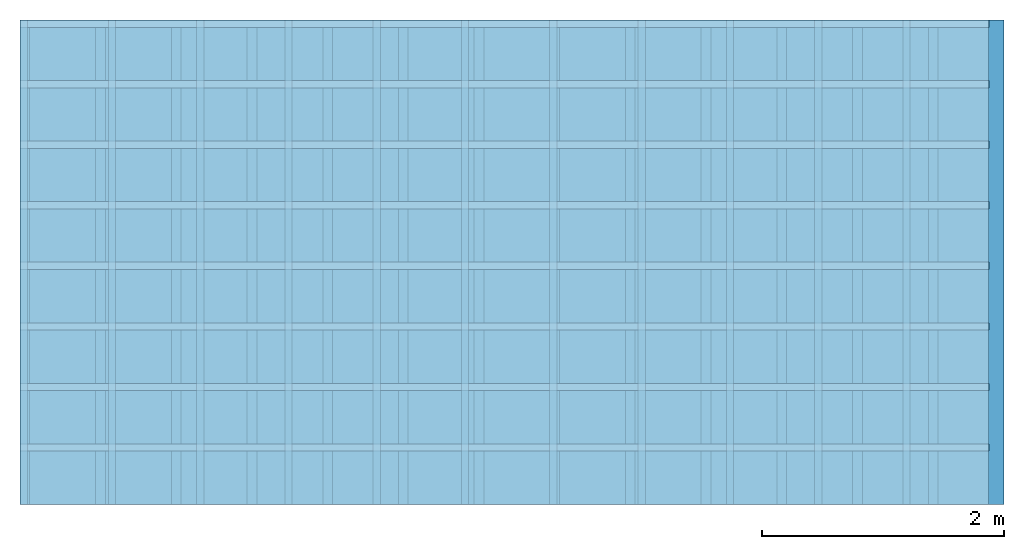
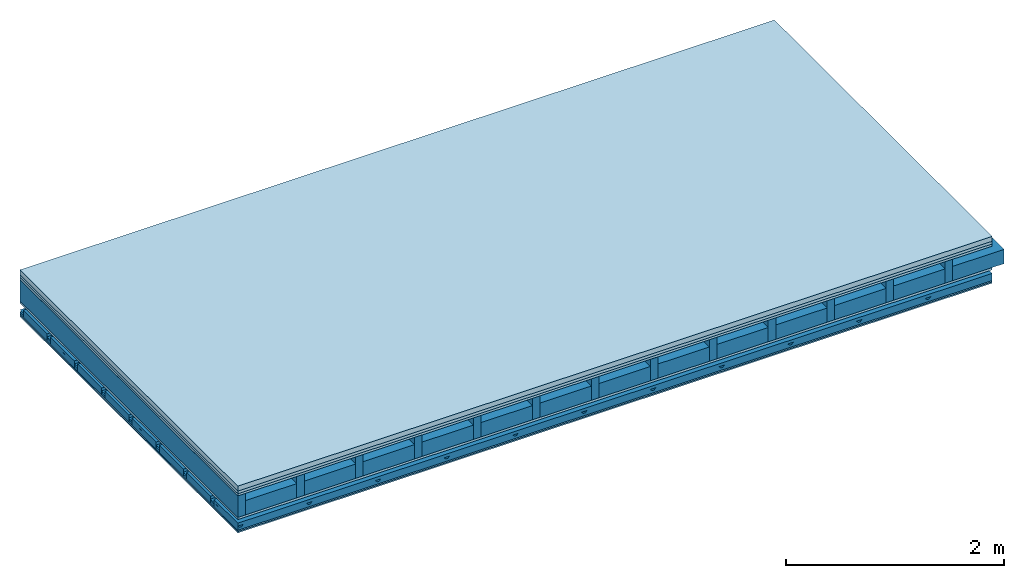
# One storey: 6 plates, 5 members, 1 element without a shape of its own.
"""IFC4 building model written with IfcOpenShell, lengths in metres."""

from ifc_helpers import new_model, si_unit, derived_unit, direction, frame, frame_2d, origin, origin_with_axes, place, context, project, spatial, polyline, rectangle, outline, extrude, material, layer, layer_set, type_object, element, aggregate, save


model = new_model("IFC4")

# Units and contexts
plan_context = context("Plan", 3, precision=1e-05, world=origin(), true_north=direction((0.0, 1.0)))
model_context = context("Model", 3, precision=1e-05, world=origin(), true_north=direction((0.0, 1.0)))
ifc_project = project(units=[si_unit("LENGTHUNIT", "METRE"), derived_unit("SOUNDPRESSUREUNIT", [(si_unit("PRESSUREUNIT", "PASCAL", prefix="MICRO"), 0)]), si_unit("ENERGYUNIT", "JOULE", prefix="MEGA"), si_unit("MASSUNIT", "GRAM", prefix="KILO"), derived_unit("THERMALTRANSMITTANCEUNIT", [(si_unit("POWERUNIT", "WATT"), 1), (si_unit("AREAUNIT", "SQUARE_METRE"), -1), (si_unit("THERMODYNAMICTEMPERATUREUNIT", "KELVIN"), -1)]), derived_unit("AREADENSITYUNIT", [(si_unit("MASSUNIT", "GRAM", prefix="KILO"), 1), (si_unit("AREAUNIT", "SQUARE_METRE"), -1)]), derived_unit("USERDEFINED", [(si_unit("ENERGYUNIT", "JOULE", prefix="MEGA"), 1), (si_unit("AREAUNIT", "SQUARE_METRE"), -1)])], contexts=[plan_context, model_context])

# Site, building, storey
site = spatial("IfcSite", under=ifc_project)
building_placement = place(None, origin())
building = spatial("IfcBuilding", under=site, at=building_placement)
storey_placement = place(building_placement, origin())
storey = spatial("IfcBuildingStorey", under=building, at=storey_placement)

# Slab, members, plates
ifc_material_1 = material(Category="04.005")
ifc_layer_1 = layer(ifc_material_1, 0.055, Name="On-material")
ifc_material_2 = material()
ifc_layer_2 = layer(ifc_material_2, 0.03, Name="Impact sound insulation")
ifc_material_3 = material(Category="07.001")
ifc_layer_3 = layer(ifc_material_3, 0.025, Name="Sub-floor")
ifc_material_4 = material(Name="Rigid, of the art")
ifc_layer_4 = layer(ifc_material_4, 0.0, Name="Bond")
ifc_layer_5 = layer(None, 0.24, Name="Supporting structure")
ifc_layer_6 = layer(ifc_material_4, 0.0, Name="Bond")
ifc_layer_7 = layer(ifc_material_3, 0.025, Name="Lower layer 1")
ifc_layer_8 = layer(None, 0.093, Name="Coupling")
ifc_layer_9 = layer(None, 0.027, Name="Battens / profiles")
ifc_material_5 = material(Category="03.007")
ifc_layer_10 = layer(ifc_material_5, 0.015, Name="Ceiling covering 1st layer")
ifc_layer_11 = layer(ifc_material_5, 0.015, Name="Ceiling covering layer 2")
ifc_material_6 = material(Name="Glued joints")
ifc_layer_12 = layer(ifc_material_6, 0.0, Name="Surface / treatment")
ifc_layer_set = layer_set([ifc_layer_1, ifc_layer_2, ifc_layer_3, ifc_layer_4, ifc_layer_5, ifc_layer_6, ifc_layer_7, ifc_layer_8, ifc_layer_9, ifc_layer_10, ifc_layer_11, ifc_layer_12])
slab_type = type_object("IfcSlabType", Name="A0760", PredefinedType="NOTDEFINED", material=ifc_layer_set)
slab_placement = place(None, frame((0.0, 0.0, 0.0), z_axis=(0.0, 0.0, -1.0), x_axis=(1.0, 0.0, 0.0)))
slab = element("IfcSlab", 1, at=slab_placement, inside=storey, type_object=slab_type, material=ifc_layer_set, Name="Slab #1")
ifc_material_7 = material()
member_1_placement = place(slab_placement, origin())
member_1 = element("IfcMember", 2, at=member_1_placement, material=ifc_material_7, Name="Supporting structure", context=plan_context, shape_type="SweptSolid", body=[
    extrude(rectangle(XDim=0.08, YDim=0.24, at=frame_2d((0.04, 0.12), x_axis=(1.0, 0.0))), frame((0.0, 4.0, 0.11), z_axis=(0.0, -1.0, 0.0), x_axis=(1.0, 0.0, 0.0)), (0.0, 0.0, 1.0), 4.0),
    extrude(rectangle(XDim=0.08, YDim=0.24, at=frame_2d((0.04, 0.12), x_axis=(1.0, 0.0))), frame((0.625, 4.0, 0.11), z_axis=(0.0, -1.0, 0.0), x_axis=(1.0, 0.0, 0.0)), (0.0, 0.0, 1.0), 4.0),
    extrude(rectangle(XDim=0.08, YDim=0.24, at=frame_2d((0.04, 0.12), x_axis=(1.0, 0.0))), frame((1.25, 4.0, 0.11), z_axis=(0.0, -1.0, 0.0), x_axis=(1.0, 0.0, 0.0)), (0.0, 0.0, 1.0), 4.0),
    extrude(rectangle(XDim=0.08, YDim=0.24, at=frame_2d((0.04, 0.12), x_axis=(1.0, 0.0))), frame((1.875, 4.0, 0.11), z_axis=(0.0, -1.0, 0.0), x_axis=(1.0, 0.0, 0.0)), (0.0, 0.0, 1.0), 4.0),
    extrude(rectangle(XDim=0.08, YDim=0.24, at=frame_2d((0.04, 0.12), x_axis=(1.0, 0.0))), frame((2.5, 4.0, 0.11), z_axis=(0.0, -1.0, 0.0), x_axis=(1.0, 0.0, 0.0)), (0.0, 0.0, 1.0), 4.0),
    extrude(rectangle(XDim=0.08, YDim=0.24, at=frame_2d((0.04, 0.12), x_axis=(1.0, 0.0))), frame((3.125, 4.0, 0.11), z_axis=(0.0, -1.0, 0.0), x_axis=(1.0, 0.0, 0.0)), (0.0, 0.0, 1.0), 4.0),
    extrude(rectangle(XDim=0.08, YDim=0.24, at=frame_2d((0.04, 0.12), x_axis=(1.0, 0.0))), frame((3.75, 4.0, 0.11), z_axis=(0.0, -1.0, 0.0), x_axis=(1.0, 0.0, 0.0)), (0.0, 0.0, 1.0), 4.0),
    extrude(rectangle(XDim=0.08, YDim=0.24, at=frame_2d((0.04, 0.12), x_axis=(1.0, 0.0))), frame((4.375, 4.0, 0.11), z_axis=(0.0, -1.0, 0.0), x_axis=(1.0, 0.0, 0.0)), (0.0, 0.0, 1.0), 4.0),
    extrude(rectangle(XDim=0.08, YDim=0.24, at=frame_2d((0.04, 0.12), x_axis=(1.0, 0.0))), frame((5.0, 4.0, 0.11), z_axis=(0.0, -1.0, 0.0), x_axis=(1.0, 0.0, 0.0)), (0.0, 0.0, 1.0), 4.0),
    extrude(rectangle(XDim=0.08, YDim=0.24, at=frame_2d((0.04, 0.12), x_axis=(1.0, 0.0))), frame((5.625, 4.0, 0.11), z_axis=(0.0, -1.0, 0.0), x_axis=(1.0, 0.0, 0.0)), (0.0, 0.0, 1.0), 4.0),
    extrude(rectangle(XDim=0.08, YDim=0.24, at=frame_2d((0.04, 0.12), x_axis=(1.0, 0.0))), frame((6.25, 4.0, 0.11), z_axis=(0.0, -1.0, 0.0), x_axis=(1.0, 0.0, 0.0)), (0.0, 0.0, 1.0), 4.0),
    extrude(rectangle(XDim=0.08, YDim=0.24, at=frame_2d((0.04, 0.12), x_axis=(1.0, 0.0))), frame((6.875, 4.0, 0.11), z_axis=(0.0, -1.0, 0.0), x_axis=(1.0, 0.0, 0.0)), (0.0, 0.0, 1.0), 4.0),
    extrude(rectangle(XDim=0.08, YDim=0.24, at=frame_2d((0.04, 0.12), x_axis=(1.0, 0.0))), frame((7.5, 4.0, 0.11), z_axis=(0.0, -1.0, 0.0), x_axis=(1.0, 0.0, 0.0)), (0.0, 0.0, 1.0), 4.0),
])
ifc_material_8 = material()
member_2_placement = place(slab_placement, origin())
member_2 = element("IfcMember", 3, at=member_2_placement, material=ifc_material_8, Name="in supporting structure", context=plan_context, shape_type="SweptSolid", body=[
    extrude(rectangle(XDim=0.545, YDim=0.16, at=frame_2d((0.2725, 0.08), x_axis=(1.0, 0.0))), frame((0.08, 4.0, 0.19), z_axis=(0.0, -1.0, 0.0), x_axis=(1.0, 0.0, 0.0)), (0.0, 0.0, 1.0), 4.0),
    extrude(rectangle(XDim=0.545, YDim=0.16, at=frame_2d((0.2725, 0.08), x_axis=(1.0, 0.0))), frame((0.705, 4.0, 0.19), z_axis=(0.0, -1.0, 0.0), x_axis=(1.0, 0.0, 0.0)), (0.0, 0.0, 1.0), 4.0),
    extrude(rectangle(XDim=0.545, YDim=0.16, at=frame_2d((0.2725, 0.08), x_axis=(1.0, 0.0))), frame((1.33, 4.0, 0.19), z_axis=(0.0, -1.0, 0.0), x_axis=(1.0, 0.0, 0.0)), (0.0, 0.0, 1.0), 4.0),
    extrude(rectangle(XDim=0.545, YDim=0.16, at=frame_2d((0.2725, 0.08), x_axis=(1.0, 0.0))), frame((1.955, 4.0, 0.19), z_axis=(0.0, -1.0, 0.0), x_axis=(1.0, 0.0, 0.0)), (0.0, 0.0, 1.0), 4.0),
    extrude(rectangle(XDim=0.545, YDim=0.16, at=frame_2d((0.2725, 0.08), x_axis=(1.0, 0.0))), frame((2.58, 4.0, 0.19), z_axis=(0.0, -1.0, 0.0), x_axis=(1.0, 0.0, 0.0)), (0.0, 0.0, 1.0), 4.0),
    extrude(rectangle(XDim=0.545, YDim=0.16, at=frame_2d((0.2725, 0.08), x_axis=(1.0, 0.0))), frame((3.205, 4.0, 0.19), z_axis=(0.0, -1.0, 0.0), x_axis=(1.0, 0.0, 0.0)), (0.0, 0.0, 1.0), 4.0),
    extrude(rectangle(XDim=0.545, YDim=0.16, at=frame_2d((0.2725, 0.08), x_axis=(1.0, 0.0))), frame((3.83, 4.0, 0.19), z_axis=(0.0, -1.0, 0.0), x_axis=(1.0, 0.0, 0.0)), (0.0, 0.0, 1.0), 4.0),
    extrude(rectangle(XDim=0.545, YDim=0.16, at=frame_2d((0.2725, 0.08), x_axis=(1.0, 0.0))), frame((4.455, 4.0, 0.19), z_axis=(0.0, -1.0, 0.0), x_axis=(1.0, 0.0, 0.0)), (0.0, 0.0, 1.0), 4.0),
    extrude(rectangle(XDim=0.545, YDim=0.16, at=frame_2d((0.2725, 0.08), x_axis=(1.0, 0.0))), frame((5.08, 4.0, 0.19), z_axis=(0.0, -1.0, 0.0), x_axis=(1.0, 0.0, 0.0)), (0.0, 0.0, 1.0), 4.0),
    extrude(rectangle(XDim=0.545, YDim=0.16, at=frame_2d((0.2725, 0.08), x_axis=(1.0, 0.0))), frame((5.705, 4.0, 0.19), z_axis=(0.0, -1.0, 0.0), x_axis=(1.0, 0.0, 0.0)), (0.0, 0.0, 1.0), 4.0),
    extrude(rectangle(XDim=0.545, YDim=0.16, at=frame_2d((0.2725, 0.08), x_axis=(1.0, 0.0))), frame((6.33, 4.0, 0.19), z_axis=(0.0, -1.0, 0.0), x_axis=(1.0, 0.0, 0.0)), (0.0, 0.0, 1.0), 4.0),
    extrude(rectangle(XDim=0.545, YDim=0.16, at=frame_2d((0.2725, 0.08), x_axis=(1.0, 0.0))), frame((6.955, 4.0, 0.19), z_axis=(0.0, -1.0, 0.0), x_axis=(1.0, 0.0, 0.0)), (0.0, 0.0, 1.0), 4.0),
    extrude(rectangle(XDim=0.545, YDim=0.16, at=frame_2d((0.2725, 0.08), x_axis=(1.0, 0.0))), frame((7.58, 4.0, 0.19), z_axis=(0.0, -1.0, 0.0), x_axis=(1.0, 0.0, 0.0)), (0.0, 0.0, 1.0), 4.0),
])
ifc_material_9 = material()
member_3_placement = place(slab_placement, origin())
member_3 = element("IfcMember", 4, at=member_3_placement, material=ifc_material_9, Name="Coupling", context=plan_context, shape_type="SweptSolid", body=[
    extrude(outline(polyline([(0.0, 0.0), (0.06, 0.0), (0.04, 0.02), (0.02, 0.02), (0.0, 0.0)])), frame((0.0, 4.0, 0.448), z_axis=(0.0, -1.0, 0.0), x_axis=(1.0, 0.0, 0.0)), (0.0, 0.0, 1.0), 4.0),
    extrude(outline(polyline([(0.0, 0.0), (0.06, 0.0), (0.04, 0.02), (0.02, 0.02), (0.0, 0.0)])), frame((0.729, 4.0, 0.448), z_axis=(0.0, -1.0, 0.0), x_axis=(1.0, 0.0, 0.0)), (0.0, 0.0, 1.0), 4.0),
    extrude(outline(polyline([(0.0, 0.0), (0.06, 0.0), (0.04, 0.02), (0.02, 0.02), (0.0, 0.0)])), frame((1.458, 4.0, 0.448), z_axis=(0.0, -1.0, 0.0), x_axis=(1.0, 0.0, 0.0)), (0.0, 0.0, 1.0), 4.0),
    extrude(outline(polyline([(0.0, 0.0), (0.06, 0.0), (0.04, 0.02), (0.02, 0.02), (0.0, 0.0)])), frame((2.187, 4.0, 0.448), z_axis=(0.0, -1.0, 0.0), x_axis=(1.0, 0.0, 0.0)), (0.0, 0.0, 1.0), 4.0),
    extrude(outline(polyline([(0.0, 0.0), (0.06, 0.0), (0.04, 0.02), (0.02, 0.02), (0.0, 0.0)])), frame((2.916, 4.0, 0.448), z_axis=(0.0, -1.0, 0.0), x_axis=(1.0, 0.0, 0.0)), (0.0, 0.0, 1.0), 4.0),
    extrude(outline(polyline([(0.0, 0.0), (0.06, 0.0), (0.04, 0.02), (0.02, 0.02), (0.0, 0.0)])), frame((3.645, 4.0, 0.448), z_axis=(0.0, -1.0, 0.0), x_axis=(1.0, 0.0, 0.0)), (0.0, 0.0, 1.0), 4.0),
    extrude(outline(polyline([(0.0, 0.0), (0.06, 0.0), (0.04, 0.02), (0.02, 0.02), (0.0, 0.0)])), frame((4.374, 4.0, 0.448), z_axis=(0.0, -1.0, 0.0), x_axis=(1.0, 0.0, 0.0)), (0.0, 0.0, 1.0), 4.0),
    extrude(outline(polyline([(0.0, 0.0), (0.06, 0.0), (0.04, 0.02), (0.02, 0.02), (0.0, 0.0)])), frame((5.103, 4.0, 0.448), z_axis=(0.0, -1.0, 0.0), x_axis=(1.0, 0.0, 0.0)), (0.0, 0.0, 1.0), 4.0),
    extrude(outline(polyline([(0.0, 0.0), (0.06, 0.0), (0.04, 0.02), (0.02, 0.02), (0.0, 0.0)])), frame((5.832, 4.0, 0.448), z_axis=(0.0, -1.0, 0.0), x_axis=(1.0, 0.0, 0.0)), (0.0, 0.0, 1.0), 4.0),
    extrude(outline(polyline([(0.0, 0.0), (0.06, 0.0), (0.04, 0.02), (0.02, 0.02), (0.0, 0.0)])), frame((6.561, 4.0, 0.448), z_axis=(0.0, -1.0, 0.0), x_axis=(1.0, 0.0, 0.0)), (0.0, 0.0, 1.0), 4.0),
    extrude(outline(polyline([(0.0, 0.0), (0.06, 0.0), (0.04, 0.02), (0.02, 0.02), (0.0, 0.0)])), frame((7.29, 4.0, 0.448), z_axis=(0.0, -1.0, 0.0), x_axis=(1.0, 0.0, 0.0)), (0.0, 0.0, 1.0), 4.0),
])
ifc_material_10 = material()
member_4_placement = place(slab_placement, origin())
member_4 = element("IfcMember", 5, at=member_4_placement, material=ifc_material_10, Name="Battens / profiles", context=plan_context, shape_type="SweptSolid", body=[
    extrude(rectangle(XDim=0.06, YDim=0.027, at=frame_2d((0.03, 0.0135), x_axis=(1.0, 0.0))), frame((0.0, 0.0, 0.468), z_axis=(1.0, 0.0, 0.0), x_axis=(0.0, 1.0, 0.0)), (0.0, 0.0, 1.0), 8.0),
    extrude(rectangle(XDim=0.06, YDim=0.027, at=frame_2d((0.03, 0.0135), x_axis=(1.0, 0.0))), frame((0.0, 0.5, 0.468), z_axis=(1.0, 0.0, 0.0), x_axis=(0.0, 1.0, 0.0)), (0.0, 0.0, 1.0), 8.0),
    extrude(rectangle(XDim=0.06, YDim=0.027, at=frame_2d((0.03, 0.0135), x_axis=(1.0, 0.0))), frame((0.0, 1.0, 0.468), z_axis=(1.0, 0.0, 0.0), x_axis=(0.0, 1.0, 0.0)), (0.0, 0.0, 1.0), 8.0),
    extrude(rectangle(XDim=0.06, YDim=0.027, at=frame_2d((0.03, 0.0135), x_axis=(1.0, 0.0))), frame((0.0, 1.5, 0.468), z_axis=(1.0, 0.0, 0.0), x_axis=(0.0, 1.0, 0.0)), (0.0, 0.0, 1.0), 8.0),
    extrude(rectangle(XDim=0.06, YDim=0.027, at=frame_2d((0.03, 0.0135), x_axis=(1.0, 0.0))), frame((0.0, 2.0, 0.468), z_axis=(1.0, 0.0, 0.0), x_axis=(0.0, 1.0, 0.0)), (0.0, 0.0, 1.0), 8.0),
    extrude(rectangle(XDim=0.06, YDim=0.027, at=frame_2d((0.03, 0.0135), x_axis=(1.0, 0.0))), frame((0.0, 2.5, 0.468), z_axis=(1.0, 0.0, 0.0), x_axis=(0.0, 1.0, 0.0)), (0.0, 0.0, 1.0), 8.0),
    extrude(rectangle(XDim=0.06, YDim=0.027, at=frame_2d((0.03, 0.0135), x_axis=(1.0, 0.0))), frame((0.0, 3.0, 0.468), z_axis=(1.0, 0.0, 0.0), x_axis=(0.0, 1.0, 0.0)), (0.0, 0.0, 1.0), 8.0),
    extrude(rectangle(XDim=0.06, YDim=0.027, at=frame_2d((0.03, 0.0135), x_axis=(1.0, 0.0))), frame((0.0, 3.5, 0.468), z_axis=(1.0, 0.0, 0.0), x_axis=(0.0, 1.0, 0.0)), (0.0, 0.0, 1.0), 8.0),
])
ifc_material_11 = material()
member_5_placement = place(slab_placement, origin())
member_5 = element("IfcMember", 6, at=member_5_placement, material=ifc_material_11, Name="Cavity", context=plan_context, shape_type="SweptSolid", body=[
    extrude(rectangle(XDim=0.44, YDim=0.08, at=frame_2d((0.22, 0.04), x_axis=(1.0, 0.0))), frame((0.0, 0.06, 0.415), z_axis=(1.0, 0.0, 0.0), x_axis=(0.0, 1.0, 0.0)), (0.0, 0.0, 1.0), 8.0),
    extrude(rectangle(XDim=0.44, YDim=0.08, at=frame_2d((0.22, 0.04), x_axis=(1.0, 0.0))), frame((0.0, 0.56, 0.415), z_axis=(1.0, 0.0, 0.0), x_axis=(0.0, 1.0, 0.0)), (0.0, 0.0, 1.0), 8.0),
    extrude(rectangle(XDim=0.44, YDim=0.08, at=frame_2d((0.22, 0.04), x_axis=(1.0, 0.0))), frame((0.0, 1.06, 0.415), z_axis=(1.0, 0.0, 0.0), x_axis=(0.0, 1.0, 0.0)), (0.0, 0.0, 1.0), 8.0),
    extrude(rectangle(XDim=0.44, YDim=0.08, at=frame_2d((0.22, 0.04), x_axis=(1.0, 0.0))), frame((0.0, 1.56, 0.415), z_axis=(1.0, 0.0, 0.0), x_axis=(0.0, 1.0, 0.0)), (0.0, 0.0, 1.0), 8.0),
    extrude(rectangle(XDim=0.44, YDim=0.08, at=frame_2d((0.22, 0.04), x_axis=(1.0, 0.0))), frame((0.0, 2.06, 0.415), z_axis=(1.0, 0.0, 0.0), x_axis=(0.0, 1.0, 0.0)), (0.0, 0.0, 1.0), 8.0),
    extrude(rectangle(XDim=0.44, YDim=0.08, at=frame_2d((0.22, 0.04), x_axis=(1.0, 0.0))), frame((0.0, 2.56, 0.415), z_axis=(1.0, 0.0, 0.0), x_axis=(0.0, 1.0, 0.0)), (0.0, 0.0, 1.0), 8.0),
    extrude(rectangle(XDim=0.44, YDim=0.08, at=frame_2d((0.22, 0.04), x_axis=(1.0, 0.0))), frame((0.0, 3.06, 0.415), z_axis=(1.0, 0.0, 0.0), x_axis=(0.0, 1.0, 0.0)), (0.0, 0.0, 1.0), 8.0),
    extrude(rectangle(XDim=0.44, YDim=0.08, at=frame_2d((0.22, 0.04), x_axis=(1.0, 0.0))), frame((0.0, 3.56, 0.415), z_axis=(1.0, 0.0, 0.0), x_axis=(0.0, 1.0, 0.0)), (0.0, 0.0, 1.0), 8.0),
])
plate_1_placement = place(slab_placement, origin())
plate_1 = element("IfcPlate", 7, at=plate_1_placement, material=ifc_material_1, Name="On-material", context=plan_context, shape_type="SweptSolid", body=[
    extrude(rectangle(XDim=8.0, YDim=4.0, at=frame_2d((4.0, 2.0), x_axis=(1.0, 0.0))), origin_with_axes(), (0.0, 0.0, 1.0), 0.055),
])
plate_2_placement = place(slab_placement, origin())
plate_2 = element("IfcPlate", 8, at=plate_2_placement, material=ifc_material_2, Name="Impact sound insulation", context=plan_context, shape_type="SweptSolid", body=[
    extrude(rectangle(XDim=8.0, YDim=4.0, at=frame_2d((4.0, 2.0), x_axis=(1.0, 0.0))), frame((0.0, 0.0, 0.055), z_axis=(0.0, 0.0, 1.0), x_axis=(1.0, 0.0, 0.0)), (0.0, 0.0, 1.0), 0.03),
])
plate_3_placement = place(slab_placement, origin())
plate_3 = element("IfcPlate", 9, at=plate_3_placement, material=ifc_material_3, Name="Sub-floor", context=plan_context, shape_type="SweptSolid", body=[
    extrude(rectangle(XDim=8.0, YDim=4.0, at=frame_2d((4.0, 2.0), x_axis=(1.0, 0.0))), frame((0.0, 0.0, 0.085), z_axis=(0.0, 0.0, 1.0), x_axis=(1.0, 0.0, 0.0)), (0.0, 0.0, 1.0), 0.025),
])
plate_4_placement = place(slab_placement, origin())
plate_4 = element("IfcPlate", 10, at=plate_4_placement, material=ifc_material_3, Name="Lower layer 1", context=plan_context, shape_type="SweptSolid", body=[
    extrude(rectangle(XDim=8.0, YDim=4.0, at=frame_2d((4.0, 2.0), x_axis=(1.0, 0.0))), frame((0.0, 0.0, 0.35), z_axis=(0.0, 0.0, 1.0), x_axis=(1.0, 0.0, 0.0)), (0.0, 0.0, 1.0), 0.025),
])
plate_5_placement = place(slab_placement, origin())
plate_5 = element("IfcPlate", 11, at=plate_5_placement, material=ifc_material_5, Name="Ceiling covering 1st layer", context=plan_context, shape_type="SweptSolid", body=[
    extrude(rectangle(XDim=8.0, YDim=4.0, at=frame_2d((4.0, 2.0), x_axis=(1.0, 0.0))), frame((0.0, 0.0, 0.495), z_axis=(0.0, 0.0, 1.0), x_axis=(1.0, 0.0, 0.0)), (0.0, 0.0, 1.0), 0.015),
])
plate_6_placement = place(slab_placement, origin())
plate_6 = element("IfcPlate", 12, at=plate_6_placement, material=ifc_material_5, Name="Ceiling covering layer 2", context=plan_context, shape_type="SweptSolid", body=[
    extrude(rectangle(XDim=8.0, YDim=4.0, at=frame_2d((4.0, 2.0), x_axis=(1.0, 0.0))), frame((0.0, 0.0, 0.51), z_axis=(0.0, 0.0, 1.0), x_axis=(1.0, 0.0, 0.0)), (0.0, 0.0, 1.0), 0.015),
])
aggregate(slab, [plate_1, plate_2, plate_3, member_1, member_2, plate_4, member_3, member_4, member_5, plate_5, plate_6])

save(model, "model.ifc")
